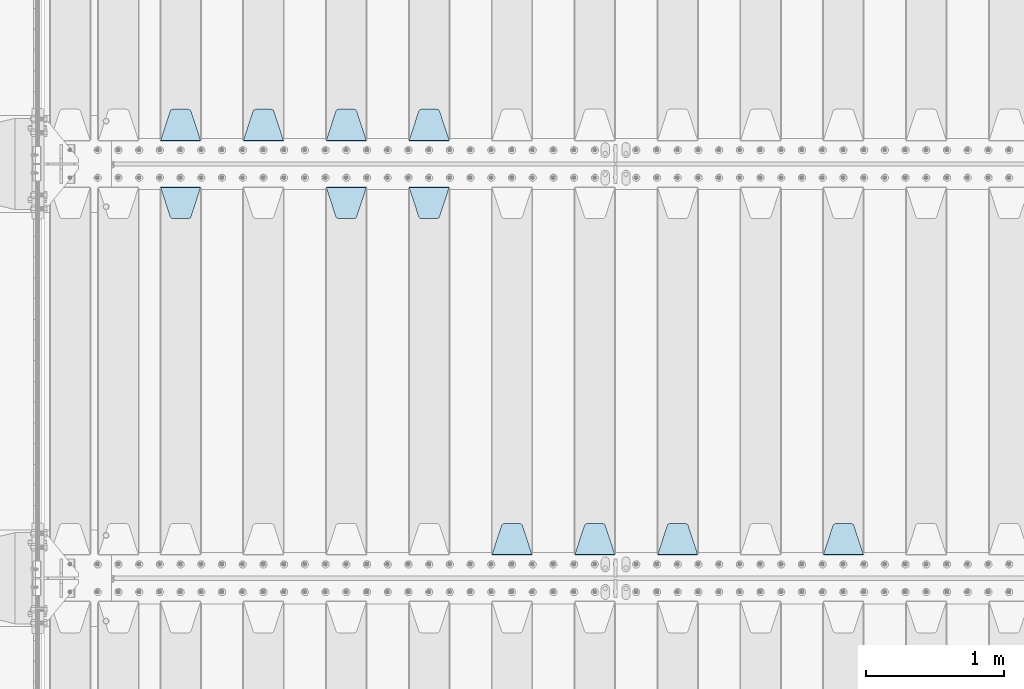
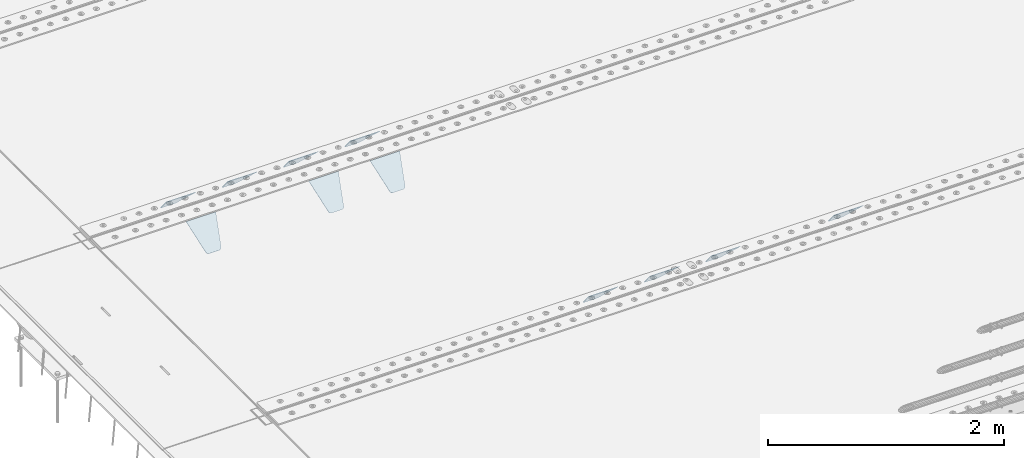
# One storey, part 195 of 240: 11 plates.
"""IFC2X3 building model written with IfcOpenShell, lengths in millimetres."""

from ifc_helpers import new_model, si_unit, frame, origin_with_axes, place, context, subcontext, project, spatial, faceted_brep, material, type_object, element, save


model = new_model("IFC2X3")

# Units and contexts
model_context = context("Model", 3, precision=1e-05, world=origin_with_axes())
body_context = subcontext(model_context, "Body", "Model", "MODEL_VIEW")
ifc_project = project(units=[si_unit("LENGTHUNIT", "METRE", prefix="MILLI"), si_unit("AREAUNIT", "SQUARE_METRE"), si_unit("VOLUMEUNIT", "CUBIC_METRE"), si_unit("MASSUNIT", "GRAM", prefix="KILO"), si_unit("TIMEUNIT", "SECOND"), si_unit("PLANEANGLEUNIT", "RADIAN"), si_unit("SOLIDANGLEUNIT", "STERADIAN"), si_unit("THERMODYNAMICTEMPERATUREUNIT", "DEGREE_CELSIUS"), si_unit("LUMINOUSINTENSITYUNIT", "LUMEN")], contexts=[model_context])

# Site, building, storey
site_placement = place(None, origin_with_axes())
site = spatial("IfcSite", under=ifc_project, at=site_placement, CompositionType="ELEMENT")
building_placement = place(site_placement, origin_with_axes())
building = spatial("IfcBuilding", under=site, at=building_placement, Name="Standard", CompositionType="ELEMENT")
storey_placement = place(building_placement, origin_with_axes())
storey = spatial("IfcBuildingStorey", under=building, at=storey_placement, Name="Undefined", CompositionType="ELEMENT", Elevation=0.0)

# Plates
ifc_material = material(Name="STEEL/S355N")
plate_type = type_object("IfcPlateType", PredefinedType="NOTDEFINED")
plate_1_placement = place(storey_placement, frame((45395.0, 30168.232233047, -1.76776695296758), z_axis=(0.0, 0.707106781186547, -0.707106781186548), x_axis=(-1.0, 0.0, 0.0)))
element("IfcPlate", 1, at=plate_1_placement, inside=storey, type_object=plate_type, material=ifc_material, context=body_context, shape_type="Brep", body=[
    faceted_brep([(0.0, -2.5, 0.0), (69.345504679477, -2.50000000000364, 300.171731424827), (69.345504679477, 2.49999999999636, 300.171731424827), (0.0, 2.5, 0.0), (70.927406119954, -2.50000000000364, 304.897442415397), (70.927406119954, 2.49999999999636, 304.897442415397), (73.3818627772271, -2.50000000000728, 309.234538108525), (73.3818627772271, 2.49999999999636, 309.234538108529), (76.6187032999587, -2.50000000000728, 313.023683126099), (76.6187032999587, 2.49999999999636, 313.023683126103), (80.5190132705029, -2.50000000000364, 316.125672595368), (80.5190132705029, 2.49999999999636, 316.125672595368), (84.9395038596849, -2.50000000000364, 318.426546230472), (84.9395038596849, 2.49999999999636, 318.426546230472), (89.7177759439219, -2.5, 319.841774983277), (89.7177759439219, 2.49999999999636, 319.841774983273), (94.6782862926484, -2.50000000000364, 320.319366455074), (94.6782862926484, 2.49999999999636, 320.319366455074), (195.321713707352, -2.50000000000364, 320.319366455074), (195.321713707352, 2.49999999999636, 320.319366455074), (200.282224056078, -2.50000000000364, 319.841774983273), (200.282224056078, 2.49999999999636, 319.841774983273), (205.060496140315, -2.50000000000364, 318.426546230472), (205.060496140315, 2.49999999999636, 318.426546230472), (209.480986729497, -2.50000000000364, 316.125672595368), (209.480986729497, 2.49999999999636, 316.125672595368), (213.381296700041, -2.50000000000728, 313.023683126099), (213.381296700041, 2.49999999999272, 313.023683126099), (216.618137222766, -2.50000000000364, 309.234538108522), (216.618137222766, 2.49999999999636, 309.234538108522), (219.072593880039, -2.50000000000364, 304.897442415397), (219.072593880039, 2.49999999999636, 304.897442415397), (220.654495320523, -2.50000000000364, 300.171731424827), (220.654495320523, 2.49999999999636, 300.171731424827), (290.0, -2.50000000000364, -3.63797880709171e-12), (290.0, 2.49999999999636, -3.63797880709171e-12)], [[[0, 1, 2, 3]], [[1, 4, 5, 2]], [[4, 6, 7, 5]], [[6, 8, 9, 7]], [[8, 10, 11, 9]], [[10, 12, 13, 11]], [[12, 14, 15, 13]], [[14, 16, 17, 15]], [[16, 18, 19, 17]], [[18, 20, 21, 19]], [[20, 22, 23, 21]], [[22, 24, 25, 23]], [[24, 26, 27, 25]], [[26, 28, 29, 27]], [[28, 30, 31, 29]], [[30, 32, 33, 31]], [[32, 34, 35, 33]], [[34, 0, 3, 35]], [[5, 7, 9, 11, 13, 15, 17, 19, 21, 23, 25, 27, 29, 31, 33, 35, 3, 2]], [[34, 32, 30, 28, 26, 24, 22, 20, 18, 16, 14, 12, 10, 8, 6, 4, 1, 0]]]),
])
plate_2_placement = place(storey_placement, frame((44795.0, 30168.232233047, -1.76776695296758), z_axis=(0.0, 0.707106781186547, -0.707106781186548), x_axis=(-1.0, 0.0, 0.0)))
element("IfcPlate", 2, at=plate_2_placement, inside=storey, type_object=plate_type, material=ifc_material, context=body_context, shape_type="Brep", body=[
    faceted_brep([(0.0, -2.5, 0.0), (69.345504679477, -2.50000000000364, 300.171731424827), (69.345504679477, 2.49999999999636, 300.171731424827), (0.0, 2.5, 0.0), (70.927406119954, -2.50000000000364, 304.897442415397), (70.927406119954, 2.49999999999636, 304.897442415397), (73.3818627772271, -2.50000000000728, 309.234538108525), (73.3818627772271, 2.49999999999636, 309.234538108529), (76.6187032999587, -2.50000000000728, 313.023683126099), (76.6187032999587, 2.49999999999636, 313.023683126103), (80.5190132705029, -2.50000000000364, 316.125672595368), (80.5190132705029, 2.49999999999636, 316.125672595368), (84.9395038596849, -2.50000000000364, 318.426546230472), (84.9395038596849, 2.49999999999636, 318.426546230472), (89.7177759439219, -2.5, 319.841774983277), (89.7177759439219, 2.49999999999636, 319.841774983273), (94.6782862926484, -2.50000000000364, 320.319366455074), (94.6782862926484, 2.49999999999636, 320.319366455074), (195.321713707352, -2.50000000000364, 320.319366455074), (195.321713707352, 2.49999999999636, 320.319366455074), (200.282224056078, -2.50000000000364, 319.841774983273), (200.282224056078, 2.49999999999636, 319.841774983273), (205.060496140315, -2.50000000000364, 318.426546230472), (205.060496140315, 2.49999999999636, 318.426546230472), (209.480986729497, -2.50000000000364, 316.125672595368), (209.480986729497, 2.49999999999636, 316.125672595368), (213.381296700041, -2.50000000000728, 313.023683126099), (213.381296700041, 2.49999999999272, 313.023683126099), (216.618137222766, -2.50000000000364, 309.234538108522), (216.618137222766, 2.49999999999636, 309.234538108522), (219.072593880039, -2.50000000000364, 304.897442415397), (219.072593880039, 2.49999999999636, 304.897442415397), (220.654495320523, -2.50000000000364, 300.171731424827), (220.654495320523, 2.49999999999636, 300.171731424827), (290.0, -2.50000000000364, -3.63797880709171e-12), (290.0, 2.49999999999636, -3.63797880709171e-12)], [[[0, 1, 2, 3]], [[1, 4, 5, 2]], [[4, 6, 7, 5]], [[6, 8, 9, 7]], [[8, 10, 11, 9]], [[10, 12, 13, 11]], [[12, 14, 15, 13]], [[14, 16, 17, 15]], [[16, 18, 19, 17]], [[18, 20, 21, 19]], [[20, 22, 23, 21]], [[22, 24, 25, 23]], [[24, 26, 27, 25]], [[26, 28, 29, 27]], [[28, 30, 31, 29]], [[30, 32, 33, 31]], [[32, 34, 35, 33]], [[34, 0, 3, 35]], [[5, 7, 9, 11, 13, 15, 17, 19, 21, 23, 25, 27, 29, 31, 33, 35, 3, 2]], [[34, 32, 30, 28, 26, 24, 22, 20, 18, 16, 14, 12, 10, 8, 6, 4, 1, 0]]]),
])
plate_3_placement = place(storey_placement, frame((44195.0, 30168.232233047, -1.76776695296758), z_axis=(0.0, 0.707106781186547, -0.707106781186548), x_axis=(-1.0, 0.0, 0.0)))
element("IfcPlate", 3, at=plate_3_placement, inside=storey, type_object=plate_type, material=ifc_material, context=body_context, shape_type="Brep", body=[
    faceted_brep([(0.0, -2.5, 0.0), (69.345504679477, -2.50000000000364, 300.171731424827), (69.345504679477, 2.49999999999636, 300.171731424827), (0.0, 2.5, 0.0), (70.927406119954, -2.50000000000364, 304.897442415397), (70.927406119954, 2.49999999999636, 304.897442415397), (73.3818627772271, -2.50000000000728, 309.234538108525), (73.3818627772271, 2.49999999999636, 309.234538108529), (76.6187032999587, -2.50000000000728, 313.023683126099), (76.6187032999587, 2.49999999999636, 313.023683126103), (80.5190132705029, -2.50000000000364, 316.125672595368), (80.5190132705029, 2.49999999999636, 316.125672595368), (84.9395038596849, -2.50000000000364, 318.426546230472), (84.9395038596849, 2.49999999999636, 318.426546230472), (89.7177759439219, -2.5, 319.841774983277), (89.7177759439219, 2.49999999999636, 319.841774983273), (94.6782862926484, -2.50000000000364, 320.319366455074), (94.6782862926484, 2.49999999999636, 320.319366455074), (195.321713707352, -2.50000000000364, 320.319366455074), (195.321713707352, 2.49999999999636, 320.319366455074), (200.282224056078, -2.50000000000364, 319.841774983273), (200.282224056078, 2.49999999999636, 319.841774983273), (205.060496140315, -2.50000000000364, 318.426546230472), (205.060496140315, 2.49999999999636, 318.426546230472), (209.480986729497, -2.50000000000364, 316.125672595368), (209.480986729497, 2.49999999999636, 316.125672595368), (213.381296700041, -2.50000000000728, 313.023683126099), (213.381296700041, 2.49999999999272, 313.023683126099), (216.618137222766, -2.50000000000364, 309.234538108522), (216.618137222766, 2.49999999999636, 309.234538108522), (219.072593880039, -2.50000000000364, 304.897442415397), (219.072593880039, 2.49999999999636, 304.897442415397), (220.654495320523, -2.50000000000364, 300.171731424827), (220.654495320523, 2.49999999999636, 300.171731424827), (290.0, -2.50000000000364, -3.63797880709171e-12), (290.0, 2.49999999999636, -3.63797880709171e-12)], [[[0, 1, 2, 3]], [[1, 4, 5, 2]], [[4, 6, 7, 5]], [[6, 8, 9, 7]], [[8, 10, 11, 9]], [[10, 12, 13, 11]], [[12, 14, 15, 13]], [[14, 16, 17, 15]], [[16, 18, 19, 17]], [[18, 20, 21, 19]], [[20, 22, 23, 21]], [[22, 24, 25, 23]], [[24, 26, 27, 25]], [[26, 28, 29, 27]], [[28, 30, 31, 29]], [[30, 32, 33, 31]], [[32, 34, 35, 33]], [[34, 0, 3, 35]], [[5, 7, 9, 11, 13, 15, 17, 19, 21, 23, 25, 27, 29, 31, 33, 35, 3, 2]], [[34, 32, 30, 28, 26, 24, 22, 20, 18, 16, 14, 12, 10, 8, 6, 4, 1, 0]]]),
])
plate_4_placement = place(storey_placement, frame((43595.0, 30168.232233047, -1.76776695296758), z_axis=(0.0, 0.707106781186547, -0.707106781186548), x_axis=(-1.0, 0.0, 0.0)))
element("IfcPlate", 4, at=plate_4_placement, inside=storey, type_object=plate_type, material=ifc_material, context=body_context, shape_type="Brep", body=[
    faceted_brep([(0.0, -2.5, 0.0), (69.345504679477, -2.50000000000364, 300.171731424827), (69.345504679477, 2.49999999999636, 300.171731424827), (0.0, 2.5, 0.0), (70.927406119954, -2.50000000000364, 304.897442415397), (70.927406119954, 2.49999999999636, 304.897442415397), (73.3818627772271, -2.50000000000728, 309.234538108525), (73.3818627772271, 2.49999999999636, 309.234538108529), (76.6187032999587, -2.50000000000728, 313.023683126099), (76.6187032999587, 2.49999999999636, 313.023683126103), (80.5190132705029, -2.50000000000364, 316.125672595368), (80.5190132705029, 2.49999999999636, 316.125672595368), (84.9395038596849, -2.50000000000364, 318.426546230472), (84.9395038596849, 2.49999999999636, 318.426546230472), (89.7177759439219, -2.5, 319.841774983277), (89.7177759439219, 2.49999999999636, 319.841774983273), (94.6782862926484, -2.50000000000364, 320.319366455074), (94.6782862926484, 2.49999999999636, 320.319366455074), (195.321713707352, -2.50000000000364, 320.319366455074), (195.321713707352, 2.49999999999636, 320.319366455074), (200.282224056078, -2.50000000000364, 319.841774983273), (200.282224056078, 2.49999999999636, 319.841774983273), (205.060496140315, -2.50000000000364, 318.426546230472), (205.060496140315, 2.49999999999636, 318.426546230472), (209.480986729497, -2.50000000000364, 316.125672595368), (209.480986729497, 2.49999999999636, 316.125672595368), (213.381296700041, -2.50000000000728, 313.023683126099), (213.381296700041, 2.49999999999272, 313.023683126099), (216.618137222766, -2.50000000000364, 309.234538108522), (216.618137222766, 2.49999999999636, 309.234538108522), (219.072593880039, -2.50000000000364, 304.897442415397), (219.072593880039, 2.49999999999636, 304.897442415397), (220.654495320523, -2.50000000000364, 300.171731424827), (220.654495320523, 2.49999999999636, 300.171731424827), (290.0, -2.50000000000364, -3.63797880709171e-12), (290.0, 2.49999999999636, -3.63797880709171e-12)], [[[0, 1, 2, 3]], [[1, 4, 5, 2]], [[4, 6, 7, 5]], [[6, 8, 9, 7]], [[8, 10, 11, 9]], [[10, 12, 13, 11]], [[12, 14, 15, 13]], [[14, 16, 17, 15]], [[16, 18, 19, 17]], [[18, 20, 21, 19]], [[20, 22, 23, 21]], [[22, 24, 25, 23]], [[24, 26, 27, 25]], [[26, 28, 29, 27]], [[28, 30, 31, 29]], [[30, 32, 33, 31]], [[32, 34, 35, 33]], [[34, 0, 3, 35]], [[5, 7, 9, 11, 13, 15, 17, 19, 21, 23, 25, 27, 29, 31, 33, 35, 3, 2]], [[34, 32, 30, 28, 26, 24, 22, 20, 18, 16, 14, 12, 10, 8, 6, 4, 1, 0]]]),
])
plate_5_placement = place(storey_placement, frame((48395.0, 27168.232233047, -1.76776695296758), z_axis=(0.0, 0.707106781186547, -0.707106781186548), x_axis=(-1.0, 0.0, 0.0)))
element("IfcPlate", 5, at=plate_5_placement, inside=storey, type_object=plate_type, material=ifc_material, context=body_context, shape_type="Brep", body=[
    faceted_brep([(0.0, -2.5, 0.0), (69.345504679477, -2.50000000000364, 300.171731424827), (69.345504679477, 2.49999999999636, 300.171731424827), (0.0, 2.5, 0.0), (70.927406119954, -2.50000000000364, 304.897442415397), (70.927406119954, 2.49999999999636, 304.897442415397), (73.3818627772271, -2.50000000000728, 309.234538108525), (73.3818627772271, 2.49999999999636, 309.234538108529), (76.6187032999587, -2.50000000000728, 313.023683126099), (76.6187032999587, 2.49999999999636, 313.023683126103), (80.5190132705029, -2.50000000000364, 316.125672595368), (80.5190132705029, 2.49999999999636, 316.125672595368), (84.9395038596849, -2.50000000000364, 318.426546230472), (84.9395038596849, 2.49999999999636, 318.426546230472), (89.7177759439219, -2.5, 319.841774983277), (89.7177759439219, 2.49999999999636, 319.841774983273), (94.6782862926484, -2.50000000000364, 320.319366455074), (94.6782862926484, 2.49999999999636, 320.319366455074), (195.321713707352, -2.50000000000364, 320.319366455074), (195.321713707352, 2.49999999999636, 320.319366455074), (200.282224056078, -2.50000000000364, 319.841774983273), (200.282224056078, 2.49999999999636, 319.841774983273), (205.060496140315, -2.50000000000364, 318.426546230472), (205.060496140315, 2.49999999999636, 318.426546230472), (209.480986729497, -2.50000000000364, 316.125672595368), (209.480986729497, 2.49999999999636, 316.125672595368), (213.381296700041, -2.50000000000728, 313.023683126099), (213.381296700041, 2.49999999999272, 313.023683126099), (216.618137222766, -2.50000000000364, 309.234538108522), (216.618137222766, 2.49999999999636, 309.234538108522), (219.072593880039, -2.50000000000364, 304.897442415397), (219.072593880039, 2.49999999999636, 304.897442415397), (220.654495320523, -2.50000000000364, 300.171731424827), (220.654495320523, 2.49999999999636, 300.171731424827), (290.0, -2.50000000000364, -3.63797880709171e-12), (290.0, 2.49999999999636, -3.63797880709171e-12)], [[[0, 1, 2, 3]], [[1, 4, 5, 2]], [[4, 6, 7, 5]], [[6, 8, 9, 7]], [[8, 10, 11, 9]], [[10, 12, 13, 11]], [[12, 14, 15, 13]], [[14, 16, 17, 15]], [[16, 18, 19, 17]], [[18, 20, 21, 19]], [[20, 22, 23, 21]], [[22, 24, 25, 23]], [[24, 26, 27, 25]], [[26, 28, 29, 27]], [[28, 30, 31, 29]], [[30, 32, 33, 31]], [[32, 34, 35, 33]], [[34, 0, 3, 35]], [[5, 7, 9, 11, 13, 15, 17, 19, 21, 23, 25, 27, 29, 31, 33, 35, 3, 2]], [[34, 32, 30, 28, 26, 24, 22, 20, 18, 16, 14, 12, 10, 8, 6, 4, 1, 0]]]),
])
plate_6_placement = place(storey_placement, frame((47195.0, 27168.232233047, -1.76776695296758), z_axis=(0.0, 0.707106781186547, -0.707106781186548), x_axis=(-1.0, 0.0, 0.0)))
element("IfcPlate", 6, at=plate_6_placement, inside=storey, type_object=plate_type, material=ifc_material, context=body_context, shape_type="Brep", body=[
    faceted_brep([(0.0, -2.5, 0.0), (69.345504679477, -2.50000000000364, 300.171731424827), (69.345504679477, 2.49999999999636, 300.171731424827), (0.0, 2.5, 0.0), (70.927406119954, -2.50000000000364, 304.897442415397), (70.927406119954, 2.49999999999636, 304.897442415397), (73.3818627772271, -2.50000000000728, 309.234538108525), (73.3818627772271, 2.49999999999636, 309.234538108529), (76.6187032999587, -2.50000000000728, 313.023683126099), (76.6187032999587, 2.49999999999636, 313.023683126103), (80.5190132705029, -2.50000000000364, 316.125672595368), (80.5190132705029, 2.49999999999636, 316.125672595368), (84.9395038596849, -2.50000000000364, 318.426546230472), (84.9395038596849, 2.49999999999636, 318.426546230472), (89.7177759439219, -2.5, 319.841774983277), (89.7177759439219, 2.49999999999636, 319.841774983273), (94.6782862926484, -2.50000000000364, 320.319366455074), (94.6782862926484, 2.49999999999636, 320.319366455074), (195.321713707352, -2.50000000000364, 320.319366455074), (195.321713707352, 2.49999999999636, 320.319366455074), (200.282224056078, -2.50000000000364, 319.841774983273), (200.282224056078, 2.49999999999636, 319.841774983273), (205.060496140315, -2.50000000000364, 318.426546230472), (205.060496140315, 2.49999999999636, 318.426546230472), (209.480986729497, -2.50000000000364, 316.125672595368), (209.480986729497, 2.49999999999636, 316.125672595368), (213.381296700041, -2.50000000000728, 313.023683126099), (213.381296700041, 2.49999999999272, 313.023683126099), (216.618137222766, -2.50000000000364, 309.234538108522), (216.618137222766, 2.49999999999636, 309.234538108522), (219.072593880039, -2.50000000000364, 304.897442415397), (219.072593880039, 2.49999999999636, 304.897442415397), (220.654495320523, -2.50000000000364, 300.171731424827), (220.654495320523, 2.49999999999636, 300.171731424827), (290.0, -2.50000000000364, -3.63797880709171e-12), (290.0, 2.49999999999636, -3.63797880709171e-12)], [[[0, 1, 2, 3]], [[1, 4, 5, 2]], [[4, 6, 7, 5]], [[6, 8, 9, 7]], [[8, 10, 11, 9]], [[10, 12, 13, 11]], [[12, 14, 15, 13]], [[14, 16, 17, 15]], [[16, 18, 19, 17]], [[18, 20, 21, 19]], [[20, 22, 23, 21]], [[22, 24, 25, 23]], [[24, 26, 27, 25]], [[26, 28, 29, 27]], [[28, 30, 31, 29]], [[30, 32, 33, 31]], [[32, 34, 35, 33]], [[34, 0, 3, 35]], [[5, 7, 9, 11, 13, 15, 17, 19, 21, 23, 25, 27, 29, 31, 33, 35, 3, 2]], [[34, 32, 30, 28, 26, 24, 22, 20, 18, 16, 14, 12, 10, 8, 6, 4, 1, 0]]]),
])
plate_7_placement = place(storey_placement, frame((46595.0, 27168.232233047, -1.76776695296758), z_axis=(0.0, 0.707106781186547, -0.707106781186548), x_axis=(-1.0, 0.0, 0.0)))
element("IfcPlate", 7, at=plate_7_placement, inside=storey, type_object=plate_type, material=ifc_material, context=body_context, shape_type="Brep", body=[
    faceted_brep([(0.0, -2.5, 0.0), (69.345504679477, -2.50000000000364, 300.171731424827), (69.345504679477, 2.49999999999636, 300.171731424827), (0.0, 2.5, 0.0), (70.927406119954, -2.50000000000364, 304.897442415397), (70.927406119954, 2.49999999999636, 304.897442415397), (73.3818627772271, -2.50000000000728, 309.234538108525), (73.3818627772271, 2.49999999999636, 309.234538108529), (76.6187032999587, -2.50000000000728, 313.023683126099), (76.6187032999587, 2.49999999999636, 313.023683126103), (80.5190132705029, -2.50000000000364, 316.125672595368), (80.5190132705029, 2.49999999999636, 316.125672595368), (84.9395038596849, -2.50000000000364, 318.426546230472), (84.9395038596849, 2.49999999999636, 318.426546230472), (89.7177759439219, -2.5, 319.841774983277), (89.7177759439219, 2.49999999999636, 319.841774983273), (94.6782862926484, -2.50000000000364, 320.319366455074), (94.6782862926484, 2.49999999999636, 320.319366455074), (195.321713707352, -2.50000000000364, 320.319366455074), (195.321713707352, 2.49999999999636, 320.319366455074), (200.282224056078, -2.50000000000364, 319.841774983273), (200.282224056078, 2.49999999999636, 319.841774983273), (205.060496140315, -2.50000000000364, 318.426546230472), (205.060496140315, 2.49999999999636, 318.426546230472), (209.480986729497, -2.50000000000364, 316.125672595368), (209.480986729497, 2.49999999999636, 316.125672595368), (213.381296700041, -2.50000000000728, 313.023683126099), (213.381296700041, 2.49999999999272, 313.023683126099), (216.618137222766, -2.50000000000364, 309.234538108522), (216.618137222766, 2.49999999999636, 309.234538108522), (219.072593880039, -2.50000000000364, 304.897442415397), (219.072593880039, 2.49999999999636, 304.897442415397), (220.654495320523, -2.50000000000364, 300.171731424827), (220.654495320523, 2.49999999999636, 300.171731424827), (290.0, -2.50000000000364, -3.63797880709171e-12), (290.0, 2.49999999999636, -3.63797880709171e-12)], [[[0, 1, 2, 3]], [[1, 4, 5, 2]], [[4, 6, 7, 5]], [[6, 8, 9, 7]], [[8, 10, 11, 9]], [[10, 12, 13, 11]], [[12, 14, 15, 13]], [[14, 16, 17, 15]], [[16, 18, 19, 17]], [[18, 20, 21, 19]], [[20, 22, 23, 21]], [[22, 24, 25, 23]], [[24, 26, 27, 25]], [[26, 28, 29, 27]], [[28, 30, 31, 29]], [[30, 32, 33, 31]], [[32, 34, 35, 33]], [[34, 0, 3, 35]], [[5, 7, 9, 11, 13, 15, 17, 19, 21, 23, 25, 27, 29, 31, 33, 35, 3, 2]], [[34, 32, 30, 28, 26, 24, 22, 20, 18, 16, 14, 12, 10, 8, 6, 4, 1, 0]]]),
])
plate_8_placement = place(storey_placement, frame((45995.0, 27168.232233047, -1.76776695296758), z_axis=(0.0, 0.707106781186547, -0.707106781186548), x_axis=(-1.0, 0.0, 0.0)))
element("IfcPlate", 8, at=plate_8_placement, inside=storey, type_object=plate_type, material=ifc_material, context=body_context, shape_type="Brep", body=[
    faceted_brep([(0.0, -2.5, 0.0), (69.345504679477, -2.50000000000364, 300.171731424827), (69.345504679477, 2.49999999999636, 300.171731424827), (0.0, 2.5, 0.0), (70.927406119954, -2.50000000000364, 304.897442415397), (70.927406119954, 2.49999999999636, 304.897442415397), (73.3818627772271, -2.50000000000728, 309.234538108525), (73.3818627772271, 2.49999999999636, 309.234538108529), (76.6187032999587, -2.50000000000728, 313.023683126099), (76.6187032999587, 2.49999999999636, 313.023683126103), (80.5190132705029, -2.50000000000364, 316.125672595368), (80.5190132705029, 2.49999999999636, 316.125672595368), (84.9395038596849, -2.50000000000364, 318.426546230472), (84.9395038596849, 2.49999999999636, 318.426546230472), (89.7177759439219, -2.5, 319.841774983277), (89.7177759439219, 2.49999999999636, 319.841774983273), (94.6782862926484, -2.50000000000364, 320.319366455074), (94.6782862926484, 2.49999999999636, 320.319366455074), (195.321713707352, -2.50000000000364, 320.319366455074), (195.321713707352, 2.49999999999636, 320.319366455074), (200.282224056078, -2.50000000000364, 319.841774983273), (200.282224056078, 2.49999999999636, 319.841774983273), (205.060496140315, -2.50000000000364, 318.426546230472), (205.060496140315, 2.49999999999636, 318.426546230472), (209.480986729497, -2.50000000000364, 316.125672595368), (209.480986729497, 2.49999999999636, 316.125672595368), (213.381296700041, -2.50000000000728, 313.023683126099), (213.381296700041, 2.49999999999272, 313.023683126099), (216.618137222766, -2.50000000000364, 309.234538108522), (216.618137222766, 2.49999999999636, 309.234538108522), (219.072593880039, -2.50000000000364, 304.897442415397), (219.072593880039, 2.49999999999636, 304.897442415397), (220.654495320523, -2.50000000000364, 300.171731424827), (220.654495320523, 2.49999999999636, 300.171731424827), (290.0, -2.50000000000364, -3.63797880709171e-12), (290.0, 2.49999999999636, -3.63797880709171e-12)], [[[0, 1, 2, 3]], [[1, 4, 5, 2]], [[4, 6, 7, 5]], [[6, 8, 9, 7]], [[8, 10, 11, 9]], [[10, 12, 13, 11]], [[12, 14, 15, 13]], [[14, 16, 17, 15]], [[16, 18, 19, 17]], [[18, 20, 21, 19]], [[20, 22, 23, 21]], [[22, 24, 25, 23]], [[24, 26, 27, 25]], [[26, 28, 29, 27]], [[28, 30, 31, 29]], [[30, 32, 33, 31]], [[32, 34, 35, 33]], [[34, 0, 3, 35]], [[5, 7, 9, 11, 13, 15, 17, 19, 21, 23, 25, 27, 29, 31, 33, 35, 3, 2]], [[34, 32, 30, 28, 26, 24, 22, 20, 18, 16, 14, 12, 10, 8, 6, 4, 1, 0]]]),
])
plate_9_placement = place(storey_placement, frame((45105.0, 29831.767766956, -1.76776695296758), z_axis=(0.0, -0.707106781186547, -0.707106781186548), x_axis=(1.0, 0.0, 0.0)))
element("IfcPlate", 9, at=plate_9_placement, inside=storey, type_object=plate_type, material=ifc_material, context=body_context, shape_type="Brep", body=[
    faceted_brep([(0.0, -2.5, 0.0), (69.345504679477, -2.50000000000364, 300.171731424827), (69.345504679477, 2.49999999999636, 300.171731424827), (0.0, 2.5, 0.0), (70.927406119954, -2.50000000000364, 304.897442415397), (70.927406119954, 2.49999999999636, 304.897442415397), (73.3818627772271, -2.50000000000728, 309.234538108525), (73.3818627772271, 2.49999999999636, 309.234538108529), (76.6187032999587, -2.50000000000728, 313.023683126099), (76.6187032999587, 2.49999999999636, 313.023683126103), (80.5190132705029, -2.50000000000364, 316.125672595368), (80.5190132705029, 2.49999999999636, 316.125672595368), (84.9395038596849, -2.50000000000364, 318.426546230472), (84.9395038596849, 2.49999999999636, 318.426546230472), (89.7177759439219, -2.5, 319.841774983277), (89.7177759439219, 2.49999999999636, 319.841774983273), (94.6782862926484, -2.50000000000364, 320.319366455074), (94.6782862926484, 2.49999999999636, 320.319366455074), (195.321713707352, -2.50000000000364, 320.319366455074), (195.321713707352, 2.49999999999636, 320.319366455074), (200.282224056078, -2.50000000000364, 319.841774983273), (200.282224056078, 2.49999999999636, 319.841774983273), (205.060496140315, -2.50000000000364, 318.426546230472), (205.060496140315, 2.49999999999636, 318.426546230472), (209.480986729497, -2.50000000000364, 316.125672595368), (209.480986729497, 2.49999999999636, 316.125672595368), (213.381296700041, -2.50000000000728, 313.023683126099), (213.381296700041, 2.49999999999272, 313.023683126099), (216.618137222766, -2.50000000000364, 309.234538108522), (216.618137222766, 2.49999999999636, 309.234538108522), (219.072593880039, -2.50000000000364, 304.897442415397), (219.072593880039, 2.49999999999636, 304.897442415397), (220.654495320523, -2.50000000000364, 300.171731424827), (220.654495320523, 2.49999999999636, 300.171731424827), (290.0, -2.50000000000364, -3.63797880709171e-12), (290.0, 2.49999999999636, -3.63797880709171e-12)], [[[0, 1, 2, 3]], [[1, 4, 5, 2]], [[4, 6, 7, 5]], [[6, 8, 9, 7]], [[8, 10, 11, 9]], [[10, 12, 13, 11]], [[12, 14, 15, 13]], [[14, 16, 17, 15]], [[16, 18, 19, 17]], [[18, 20, 21, 19]], [[20, 22, 23, 21]], [[22, 24, 25, 23]], [[24, 26, 27, 25]], [[26, 28, 29, 27]], [[28, 30, 31, 29]], [[30, 32, 33, 31]], [[32, 34, 35, 33]], [[34, 0, 3, 35]], [[5, 7, 9, 11, 13, 15, 17, 19, 21, 23, 25, 27, 29, 31, 33, 35, 3, 2]], [[34, 32, 30, 28, 26, 24, 22, 20, 18, 16, 14, 12, 10, 8, 6, 4, 1, 0]]]),
])
plate_10_placement = place(storey_placement, frame((44505.0, 29831.767766956, -1.76776695296758), z_axis=(0.0, -0.707106781186547, -0.707106781186548), x_axis=(1.0, 0.0, 0.0)))
element("IfcPlate", 10, at=plate_10_placement, inside=storey, type_object=plate_type, material=ifc_material, context=body_context, shape_type="Brep", body=[
    faceted_brep([(0.0, -2.5, 0.0), (69.345504679477, -2.50000000000364, 300.171731424827), (69.345504679477, 2.49999999999636, 300.171731424827), (0.0, 2.5, 0.0), (70.927406119954, -2.50000000000364, 304.897442415397), (70.927406119954, 2.49999999999636, 304.897442415397), (73.3818627772271, -2.50000000000728, 309.234538108525), (73.3818627772271, 2.49999999999636, 309.234538108529), (76.6187032999587, -2.50000000000728, 313.023683126099), (76.6187032999587, 2.49999999999636, 313.023683126103), (80.5190132705029, -2.50000000000364, 316.125672595368), (80.5190132705029, 2.49999999999636, 316.125672595368), (84.9395038596849, -2.50000000000364, 318.426546230472), (84.9395038596849, 2.49999999999636, 318.426546230472), (89.7177759439219, -2.5, 319.841774983277), (89.7177759439219, 2.49999999999636, 319.841774983273), (94.6782862926484, -2.50000000000364, 320.319366455074), (94.6782862926484, 2.49999999999636, 320.319366455074), (195.321713707352, -2.50000000000364, 320.319366455074), (195.321713707352, 2.49999999999636, 320.319366455074), (200.282224056078, -2.50000000000364, 319.841774983273), (200.282224056078, 2.49999999999636, 319.841774983273), (205.060496140315, -2.50000000000364, 318.426546230472), (205.060496140315, 2.49999999999636, 318.426546230472), (209.480986729497, -2.50000000000364, 316.125672595368), (209.480986729497, 2.49999999999636, 316.125672595368), (213.381296700041, -2.50000000000728, 313.023683126099), (213.381296700041, 2.49999999999272, 313.023683126099), (216.618137222766, -2.50000000000364, 309.234538108522), (216.618137222766, 2.49999999999636, 309.234538108522), (219.072593880039, -2.50000000000364, 304.897442415397), (219.072593880039, 2.49999999999636, 304.897442415397), (220.654495320523, -2.50000000000364, 300.171731424827), (220.654495320523, 2.49999999999636, 300.171731424827), (290.0, -2.50000000000364, -3.63797880709171e-12), (290.0, 2.49999999999636, -3.63797880709171e-12)], [[[0, 1, 2, 3]], [[1, 4, 5, 2]], [[4, 6, 7, 5]], [[6, 8, 9, 7]], [[8, 10, 11, 9]], [[10, 12, 13, 11]], [[12, 14, 15, 13]], [[14, 16, 17, 15]], [[16, 18, 19, 17]], [[18, 20, 21, 19]], [[20, 22, 23, 21]], [[22, 24, 25, 23]], [[24, 26, 27, 25]], [[26, 28, 29, 27]], [[28, 30, 31, 29]], [[30, 32, 33, 31]], [[32, 34, 35, 33]], [[34, 0, 3, 35]], [[5, 7, 9, 11, 13, 15, 17, 19, 21, 23, 25, 27, 29, 31, 33, 35, 3, 2]], [[34, 32, 30, 28, 26, 24, 22, 20, 18, 16, 14, 12, 10, 8, 6, 4, 1, 0]]]),
])
plate_11_placement = place(storey_placement, frame((43305.0, 29831.767766956, -1.76776695296758), z_axis=(0.0, -0.707106781186547, -0.707106781186548), x_axis=(1.0, 0.0, 0.0)))
element("IfcPlate", 11, at=plate_11_placement, inside=storey, type_object=plate_type, material=ifc_material, context=body_context, shape_type="Brep", body=[
    faceted_brep([(0.0, -2.5, 0.0), (69.345504679477, -2.50000000000364, 300.171731424827), (69.345504679477, 2.49999999999636, 300.171731424827), (0.0, 2.5, 0.0), (70.927406119954, -2.50000000000364, 304.897442415397), (70.927406119954, 2.49999999999636, 304.897442415397), (73.3818627772271, -2.50000000000728, 309.234538108525), (73.3818627772271, 2.49999999999636, 309.234538108529), (76.6187032999587, -2.50000000000728, 313.023683126099), (76.6187032999587, 2.49999999999636, 313.023683126103), (80.5190132705029, -2.50000000000364, 316.125672595368), (80.5190132705029, 2.49999999999636, 316.125672595368), (84.9395038596849, -2.50000000000364, 318.426546230472), (84.9395038596849, 2.49999999999636, 318.426546230472), (89.7177759439219, -2.5, 319.841774983277), (89.7177759439219, 2.49999999999636, 319.841774983273), (94.6782862926484, -2.50000000000364, 320.319366455074), (94.6782862926484, 2.49999999999636, 320.319366455074), (195.321713707352, -2.50000000000364, 320.319366455074), (195.321713707352, 2.49999999999636, 320.319366455074), (200.282224056078, -2.50000000000364, 319.841774983273), (200.282224056078, 2.49999999999636, 319.841774983273), (205.060496140315, -2.50000000000364, 318.426546230472), (205.060496140315, 2.49999999999636, 318.426546230472), (209.480986729497, -2.50000000000364, 316.125672595368), (209.480986729497, 2.49999999999636, 316.125672595368), (213.381296700041, -2.50000000000728, 313.023683126099), (213.381296700041, 2.49999999999272, 313.023683126099), (216.618137222766, -2.50000000000364, 309.234538108522), (216.618137222766, 2.49999999999636, 309.234538108522), (219.072593880039, -2.50000000000364, 304.897442415397), (219.072593880039, 2.49999999999636, 304.897442415397), (220.654495320523, -2.50000000000364, 300.171731424827), (220.654495320523, 2.49999999999636, 300.171731424827), (290.0, -2.50000000000364, -3.63797880709171e-12), (290.0, 2.49999999999636, -3.63797880709171e-12)], [[[0, 1, 2, 3]], [[1, 4, 5, 2]], [[4, 6, 7, 5]], [[6, 8, 9, 7]], [[8, 10, 11, 9]], [[10, 12, 13, 11]], [[12, 14, 15, 13]], [[14, 16, 17, 15]], [[16, 18, 19, 17]], [[18, 20, 21, 19]], [[20, 22, 23, 21]], [[22, 24, 25, 23]], [[24, 26, 27, 25]], [[26, 28, 29, 27]], [[28, 30, 31, 29]], [[30, 32, 33, 31]], [[32, 34, 35, 33]], [[34, 0, 3, 35]], [[5, 7, 9, 11, 13, 15, 17, 19, 21, 23, 25, 27, 29, 31, 33, 35, 3, 2]], [[34, 32, 30, 28, 26, 24, 22, 20, 18, 16, 14, 12, 10, 8, 6, 4, 1, 0]]]),
])

save(model, "model.ifc")
